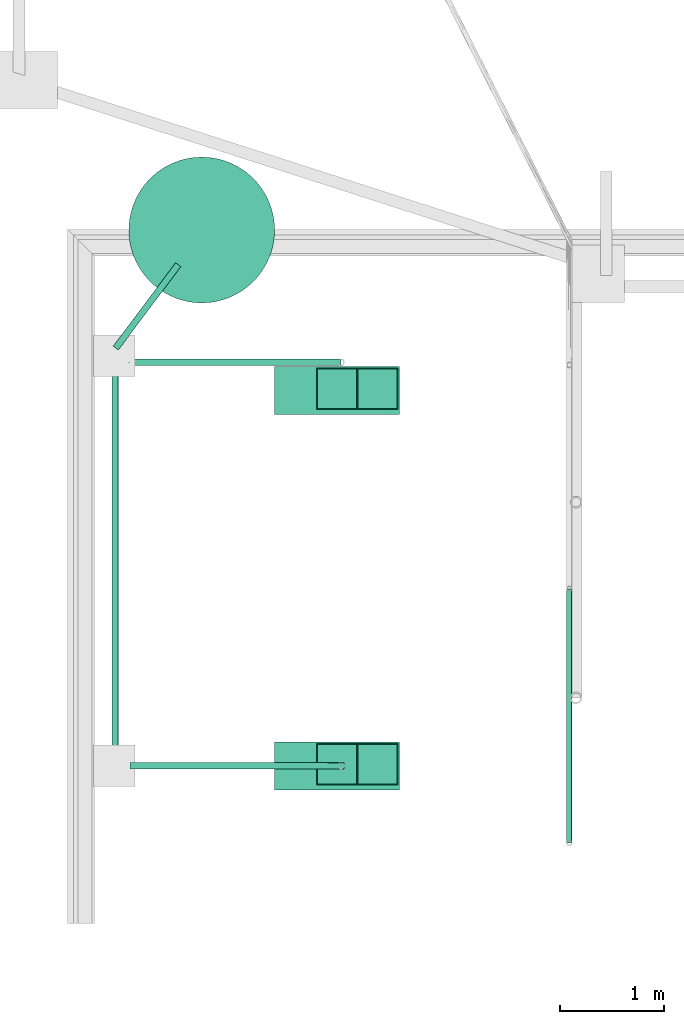
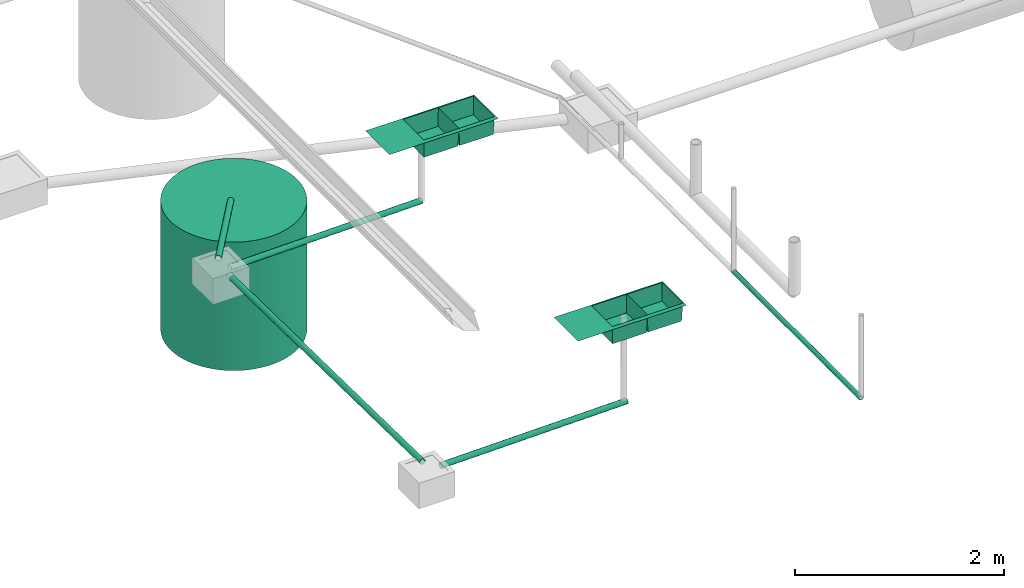
# One storey, part 4 of 15: 5 pipe segments, 2 sanitary terminals, 1 waste terminal.
"""IFC4X3_ADD2 building model written with IfcOpenShell, lengths in metres."""

from ifc_helpers import new_model, entity, si_unit, converted_unit, frame, origin_with_axes, origin_2d_with_axis, place, context, subcontext, project, spatial, circle, hollow_circle, extrude, clip, halfspace, polygons, source, transform, mapped, material, material_profile, profile_set, profile_usage, type_object, type_shapes, element, save


model = new_model("IFC4X3_ADD2")

# Units and contexts
model_context = context("Model", 3, precision=1e-05, world=origin_with_axes())
plan_context = context("Plan", 2, precision=1e-05, world=origin_2d_with_axis())
body_context = subcontext(model_context, "Body", "Model", "MODEL_VIEW")
ifc_project = project(units=[si_unit("VOLUMEUNIT", "CUBIC_METRE"), si_unit("LENGTHUNIT", "METRE"), converted_unit("PLANEANGLEUNIT", "degree", entity("IfcReal", 0.0174532925199433), si_unit("PLANEANGLEUNIT", "RADIAN"), dimensions=[0, 0, 0, 0, 0, 0, 0]), si_unit("AREAUNIT", "SQUARE_METRE")], contexts=[model_context, plan_context])

# Site, building, storey
site_placement = place(None, origin_with_axes())
site = spatial("IfcSite", under=ifc_project, at=site_placement)
building_placement = place(site_placement, origin_with_axes())
building = spatial("IfcBuilding", under=site, at=building_placement, Name="Building")
storey_placement = place(building_placement, origin_with_axes())
storey = spatial("IfcBuildingStorey", under=building, at=storey_placement, Name="Plumbing")

# Sanitary terminals
ifc_material_1 = material(Name="Steel Chrome", Category="Finishes")
sanitary_terminal_type = type_object("IfcSanitaryTerminalType", Name="2BOWL_SINK_1.2x.46x.21", PredefinedType="SINK", material=ifc_material_1)
shared_shape = source(origin_with_axes(), body_context, "Body", "Tessellation", [
    polygons([(0.0, 0.0, -2.50339500240671e-08), (0.0, 0.46000000834465, -2.50339500240671e-08), (1.20000004768372, 0.0, -2.50339500240671e-08), (1.20000004768372, 0.46000000834465, -2.50339500240671e-08), (1.18490755558014, 0.444907486438751, -2.50339500240671e-08), (0.0150925163179636, 0.412476718425751, -2.50339500240671e-08), (0.0150925163179636, 0.0150925163179636, -2.50339500240671e-08), (1.18490755558014, 0.0150925163179636, -2.50339500240671e-08), (0.405030876398087, 0.412476718425751, -2.50339500240671e-08), (0.794969201087952, 0.412476718425751, -2.50339500240671e-08), (0.794969201087952, 0.0150925163179636, -2.50339500240671e-08), (0.405030846595764, 0.0150925163179636, -2.50339500240671e-08), (0.800000011920929, 0.46000000834465, -2.50339500240671e-08), (0.400000005960464, 0.46000000834465, -2.50339500240671e-08), (0.400000035762787, 0.0, -2.50339500240671e-08), (0.800000071525574, 0.0, -2.50339500240671e-08), (0.396583825349808, 0.404029667377472, -0.210000023245811), (0.0235395655035973, 0.404029667377472, -0.210000023245811), (0.0235395655035973, 0.0235395655035973, -0.210000023245811), (0.396583795547485, 0.0235395655035973, -0.210000023245811), (0.786522150039673, 0.404029667377472, -0.210000023245811), (0.413477927446365, 0.404029667377472, -0.210000023245811), (0.413477897644043, 0.0235395655035973, -0.210000023245811), (0.786522150039673, 0.0235395655035973, -0.210000023245811)], [[[17, 18, 19, 20]], [[14, 2, 6, 9]], [[2, 1, 7, 6]], [[16, 3, 8, 11]], [[3, 4, 5, 8]], [[1, 15, 12, 7]], [[15, 16, 11, 12]], [[4, 13, 10, 5]], [[13, 14, 9, 10]], [[5, 10, 11, 8]], [[21, 22, 23, 24]], [[9, 6, 18, 17]], [[6, 7, 19, 18]], [[7, 12, 20, 19]], [[12, 9, 17, 20]], [[10, 9, 22, 21]], [[9, 12, 23, 22]], [[12, 11, 24, 23]], [[11, 10, 21, 24]]]),
])
type_shapes(sanitary_terminal_type, [shared_shape])
for number, where, z_axis, x_axis, name in (
    (1, (7.50750875473022, 26.0828990936279, 1.36199998855591), (0.0, 0.0, 1.0), (-0.999999999999989, -1.50995802528085e-07, 0.0), "SanitaryTerminal"),
    (2, (7.50750875473022, 22.4786949157715, 1.37000000476837), (0.0, 0.0, 1.0), (-0.999999999999924, 3.89414367418765e-07, 0.0), "SanitaryTerminal"),
):
    element("IfcSanitaryTerminal", number, at=place(storey_placement, frame(where, z_axis=z_axis, x_axis=x_axis)), inside=storey, type_object=sanitary_terminal_type, Name=name, context=body_context, shape_type="MappedRepresentation", body=[
        mapped(shared_shape, transform((0.0, 0.0, 0.0), x_axis=(1.0, 0.0, 0.0), y_axis=(0.0, 1.0, 0.0), z_axis=(0.0, 0.0, 1.0), scale=1.0)),
    ])

# Waste terminal
ifc_material_2 = material(Name="Wall")
ifc_material_profile_1 = material_profile(ifc_material_2, circle(Radius=0.699999988079071))
ifc_profile_set_1 = profile_set([ifc_material_profile_1])
ifc_profile_usage_1 = profile_usage(ifc_profile_set_1, cardinal=5)
waste_terminal_type = type_object("IfcWasteTerminalType", Name="1200mm ID", PredefinedType="USERDEFINED", material=ifc_profile_set_1)
waste_terminal_placement = place(storey_placement, frame((5.60977029800415, 27.3947982788086, 1.19209289550781e-07), z_axis=(-1.50995802528084e-07, -8.74227694680472e-08, -0.999999999999985), x_axis=(-0.999999999999985, 8.74227836789019e-08, 1.50995802528084e-07)))
element("IfcWasteTerminal", 3, at=waste_terminal_placement, inside=storey, type_object=waste_terminal_type, material=ifc_profile_usage_1, Name="WasteTerminal", context=body_context, shape_type="SweptSolid", body=[
    extrude(circle(Radius=0.699999988079071), origin_with_axes(), (0.0, 0.0, 1.0), 1.5),
])

# Pipe segments
ifc_material_profile_2 = material_profile(ifc_material_2, hollow_circle(Radius=0.0253999996930361, WallThickness=0.0020000000949949))
ifc_profile_set_2 = profile_set([ifc_material_profile_2])
ifc_profile_usage_2 = profile_usage(ifc_profile_set_2)
ifc_material_profile_3 = material_profile(ifc_material_2, hollow_circle(Radius=0.0253999996930361, WallThickness=0.0020000000949949))
ifc_profile_set_3 = profile_set([ifc_material_profile_3])
pipe_segment_type_1 = type_object("IfcPipeSegmentType", Name="2inch-bath outlet", PredefinedType="FLEXIBLESEGMENT", material=ifc_profile_set_3)
pipe_segment_1_placement = place(storey_placement, frame((9.13959503173828, 21.5092372894287, 0.0252148024737835), z_axis=(-1.50995774106375e-07, 0.999999999999986, 7.54979012640422e-08), x_axis=(-0.999999999999913, -1.50995802528073e-07, 3.89414424262179e-07)))
element("IfcPipeSegment", 4, at=pipe_segment_1_placement, inside=storey, type_object=pipe_segment_type_1, material=ifc_profile_usage_2, Name="PipeSegment", context=body_context, shape_type="SweptSolid", body=[
    extrude(hollow_circle(Radius=0.0253999996930361, WallThickness=0.0020000000949949), origin_with_axes(), (0.0, 0.0, 1.0), 2.43851283622794),
])
ifc_material_3 = material()
ifc_material_profile_4 = material_profile(ifc_material_3, hollow_circle(Radius=0.031750001013279, WallThickness=0.0020000000949949))
ifc_profile_set_4 = profile_set([ifc_material_profile_4])
ifc_profile_usage_3 = profile_usage(ifc_profile_set_4)
ifc_material_profile_5 = material_profile(ifc_material_3, hollow_circle(Radius=0.031750001013279, WallThickness=0.0020000000949949))
ifc_profile_set_5 = profile_set([ifc_material_profile_5])
pipe_segment_type_2 = type_object("IfcPipeSegmentType", Name="2.5inch- Kitchen Outlet", PredefinedType="FLEXIBLESEGMENT", material=ifc_profile_set_5)
pipe_segment_2_placement = place(storey_placement, frame((7.04137468338013, 22.2486953735352, 0.300793945789337), z_axis=(-0.99984769819536, -3.09237716183448e-07, -0.0174522323312906), x_axis=(3.13916473260152e-07, -0.999999999999916, -2.65349939354542e-07)))
element("IfcPipeSegment", 5, at=pipe_segment_2_placement, inside=storey, type_object=pipe_segment_type_2, material=ifc_profile_usage_3, Name="PipeSegment", context=body_context, shape_type="Clipping", body=[
    clip(extrude(hollow_circle(Radius=0.031750001013279, WallThickness=0.0020000000949949), origin_with_axes(), (0.0, 0.0, 1.0), 2.12190705562717), halfspace(frame((2.11953420148348e-06, -0.0323413424193859, 0.0640649572014809), z_axis=(6.71544285069103e-07, -0.0174522306770086, -0.999847650527954), x_axis=(-0.999999999259683, -3.84789942902046e-05, 0.0)), False)),
])
ifc_profile_usage_4 = profile_usage(ifc_profile_set_4)
pipe_segment_3_placement = place(storey_placement, frame((6.9461817741394, 26.1231498718262, 0.299132347106934), z_axis=(-0.99984769819536, -3.09237716183448e-07, -0.0174522323312906), x_axis=(3.13916473260152e-07, -0.999999999999916, -2.65349939354542e-07)))
element("IfcPipeSegment", 6, at=pipe_segment_3_placement, inside=storey, type_object=pipe_segment_type_2, material=ifc_profile_usage_4, Name="PipeSegment", context=body_context, shape_type="SweptSolid", body=[
    extrude(hollow_circle(Radius=0.031750001013279, WallThickness=0.0020000000949949), origin_with_axes(), (0.0, 0.0, 1.0), 2.11426370891998),
])
ifc_profile_usage_5 = profile_usage(ifc_profile_set_4)
pipe_segment_4_placement = place(storey_placement, frame((4.77956008911133, 22.3466739654541, 0.299235969781876), z_axis=(-1.46341845337663e-07, 0.999847698195397, -0.0174522323312912), x_axis=(-0.999999999999953, -1.5099580252808e-07, -2.65349910932843e-07)))
element("IfcPipeSegment", 7, at=pipe_segment_4_placement, inside=storey, type_object=pipe_segment_type_2, material=ifc_profile_usage_5, Name="PipeSegment", context=body_context, shape_type="SweptSolid", body=[
    extrude(hollow_circle(Radius=0.031750001013279, WallThickness=0.0020000000949949), origin_with_axes(), (0.0, 0.0, 1.0), 3.70013327023043),
])
ifc_profile_usage_6 = profile_usage(ifc_profile_set_4)
pipe_segment_5_placement = place(storey_placement, frame((4.78372192382812, 26.2606468200684, 0.299132347106934), z_axis=(0.599324925056114, 0.800315596376028, -0.0174522320568758), x_axis=(-0.800437516465484, 0.59941620117786, -2.6534994149341e-07)))
element("IfcPipeSegment", 8, at=pipe_segment_5_placement, inside=storey, type_object=pipe_segment_type_2, material=ifc_profile_usage_6, Name="PipeSegment", context=body_context, shape_type="SweptSolid", body=[
    extrude(hollow_circle(Radius=0.031750001013279, WallThickness=0.0020000000949949), origin_with_axes(), (0.0, 0.0, 1.0), 1.00000037299462),
])

save(model, "model.ifc")
